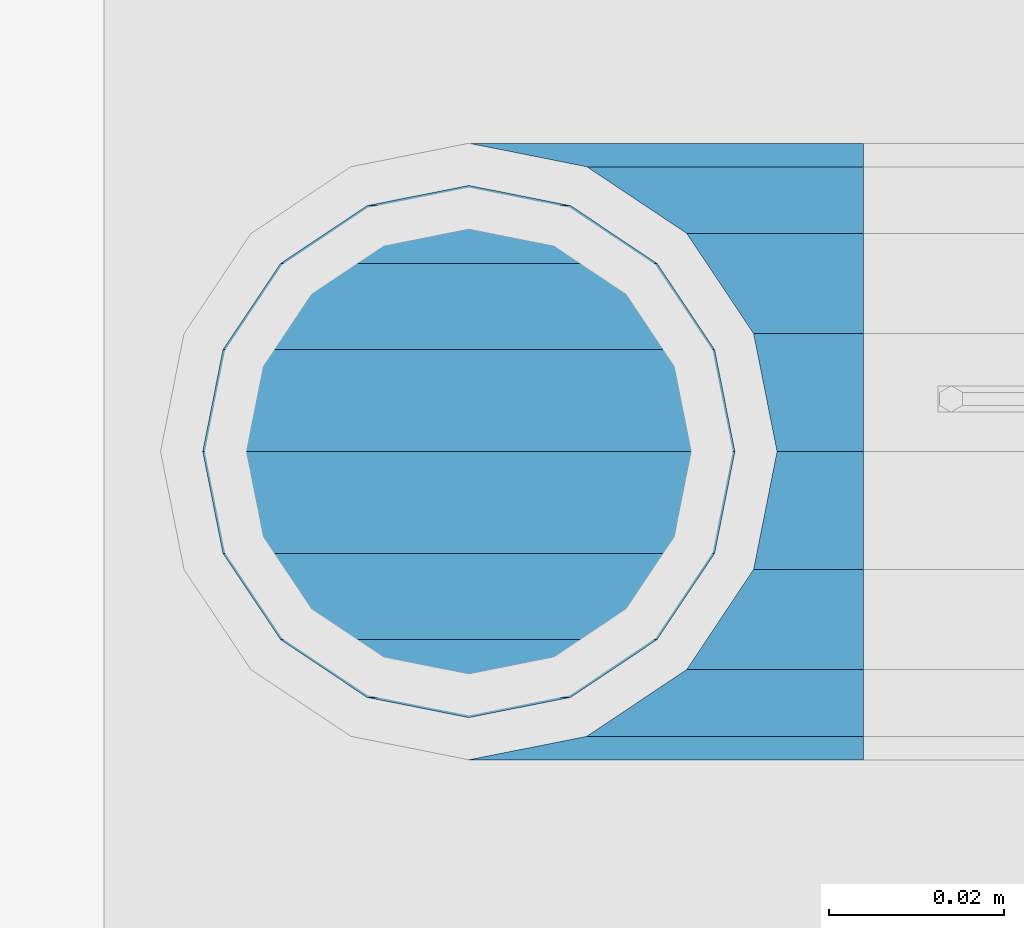
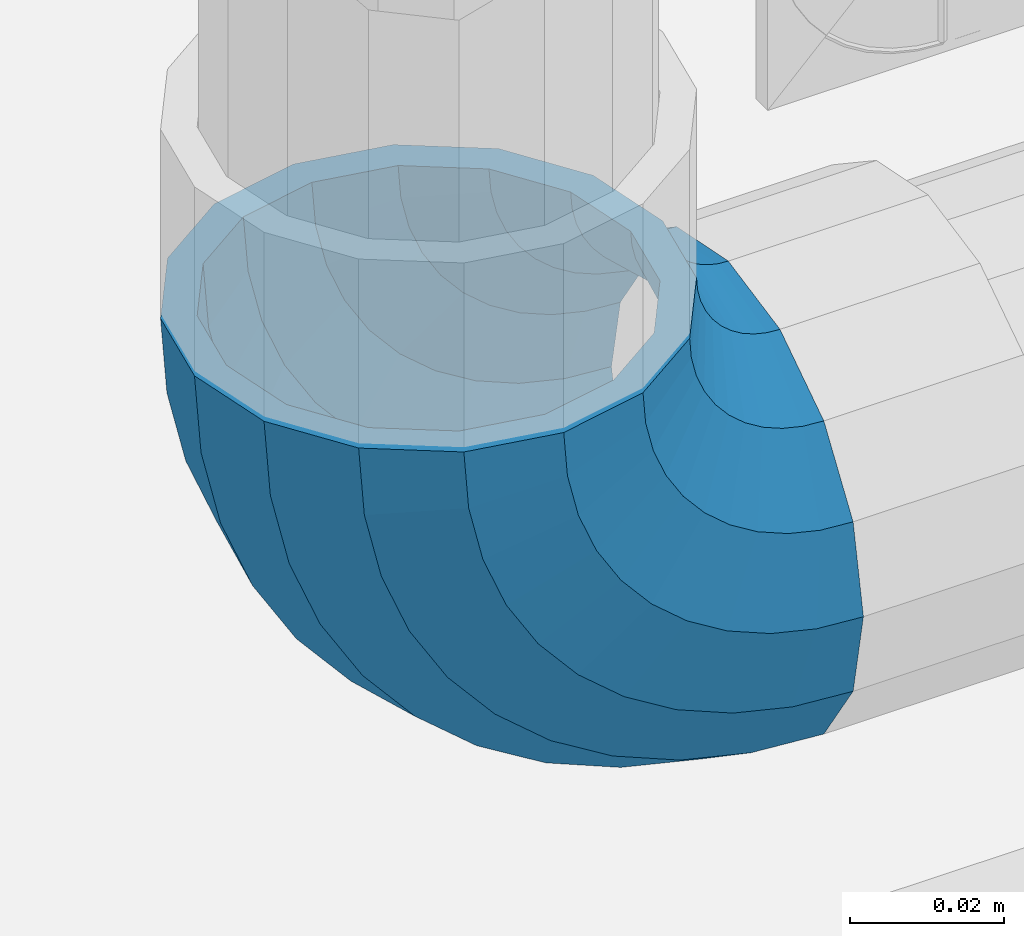
# One storey, part 127 of 193: 1 member.
"""IFC2X3 building model written with IfcOpenShell, lengths in millimetres."""

from ifc_helpers import new_model, si_unit, frame, origin_with_axes, place, context, subcontext, project, spatial, faceted_brep, material, type_object, element, save


model = new_model("IFC2X3")

# Units and contexts
model_context = context("Model", 3, precision=1e-05, world=origin_with_axes())
body_context = subcontext(model_context, "Body", "Model", "MODEL_VIEW")
ifc_project = project(units=[si_unit("LENGTHUNIT", "METRE", prefix="MILLI"), si_unit("AREAUNIT", "SQUARE_METRE"), si_unit("VOLUMEUNIT", "CUBIC_METRE"), si_unit("MASSUNIT", "GRAM", prefix="KILO"), si_unit("TIMEUNIT", "SECOND"), si_unit("PLANEANGLEUNIT", "RADIAN"), si_unit("SOLIDANGLEUNIT", "STERADIAN"), si_unit("THERMODYNAMICTEMPERATUREUNIT", "DEGREE_CELSIUS"), si_unit("LUMINOUSINTENSITYUNIT", "LUMEN")], contexts=[model_context])

# Site, building, storey
site_placement = place(None, origin_with_axes())
site = spatial("IfcSite", under=ifc_project, at=site_placement, CompositionType="ELEMENT")
building_placement = place(site_placement, origin_with_axes())
building = spatial("IfcBuilding", under=site, at=building_placement, Name="Standard", CompositionType="ELEMENT")
storey_placement = place(building_placement, origin_with_axes())
storey = spatial("IfcBuildingStorey", under=building, at=storey_placement, Name="Undefined", CompositionType="ELEMENT", Elevation=0.0)

# Member
ifc_material = material(Name="Misc_Undefined")
member_type = type_object("IfcMemberType", PredefinedType="NOTDEFINED")
member_placement = place(storey_placement, frame((-30118.39, 28664.5, 343.170000000002), z_axis=(-0.707106781186548, 0.0, -0.707106781186548), x_axis=(0.707106781186548, 0.0, -0.707106781186548)))
element("IfcMember", 1, at=member_placement, inside=storey, type_object=member_type, material=ifc_material, context=body_context, shape_type="Brep", body=[
    faceted_brep([(0.0, -35.1500000000015, 0.0), (9.51152146007007, -32.4743655677703, -9.51152146007007), (13.2759578763398, -32.4743655677703, -6.2963890252795), (5.36946880023243, -35.1500000000015, 4.58595959347804), (17.5749999999971, -24.8548033587067, -17.5750000000007), (19.978755663109, -24.8548033587067, -15.5219987155651), (22.9628441077002, -13.4513226476338, -22.9628441077002), (24.4574219585229, -13.4513226476338, -21.6863540323939), (24.8548033587067, 0.0, -24.8548033587067), (26.0301204183124, 0.0, -23.850987758804), (22.9628441077002, 13.4513226476338, -22.9628441077002), (24.4574219585229, 13.4513226476338, -21.6863540323939), (17.5749999999971, 24.8548033587067, -17.5750000000007), (19.978755663109, 24.8548033587067, -15.5219987155651), (9.51152146007007, 32.4743655677703, -9.51152146007007), (13.2759578763398, 32.4743655677703, -6.2963890252795), (0.0, 35.1500000000015, 0.0), (5.36946880023243, 35.1500000000015, 4.58595959347804), (-9.51152146007007, 32.4743655677703, 9.51152146007007), (-2.53702027587133, 32.4743655677703, 15.4683082122356), (-17.5750000000007, 24.8548033587067, 17.5750000000007), (-9.23981806264419, 24.8548033587067, 24.6939179025212), (-22.9628441077039, 13.4513226476338, 22.9628441077002), (-13.718484358058, 13.4513226476338, 30.8582732193499), (-24.8548033587103, 0.0, 24.8548033587067), (-15.2911828178476, 0.0, 33.02290694576), (-22.9628441077039, -13.4513226476338, 22.9628441077002), (-13.718484358058, -13.4513226476338, 30.8582732193499), (-17.5750000000007, -24.8548033587067, 17.5750000000007), (-9.23981806264419, -24.8548033587067, 24.6939179025212), (-9.51152146007007, -32.4743655677703, 9.51152146007007), (-2.53702027587133, -32.4743655677703, 15.4683082122356), (0.0, -30.3499999999985, 0.0), (-8.2126508197216, -28.0397438117179, 8.21265081971796), (-1.45732902223972, -28.0397438117179, 13.9822406910389), (5.36946880023243, -30.3499999999985, 4.58595959347804), (-15.1749999999993, -21.46069080901, 15.1749999999993), (-7.24480876131565, -21.46069080901, 21.9480231689959), (-19.827092992, -11.614442172282, 19.827092992), (-11.1118790903529, -11.614442172282, 27.2705888550809), (-21.4606908090136, 0.0, 21.46069080901), (-12.4698136068437, 0.0, 29.139625372758), (-19.827092992, 11.614442172282, 19.827092992), (-11.1118790903529, 11.614442172282, 27.2705888550809), (-15.1749999999993, 21.46069080901, 15.1749999999993), (-7.24480876131565, 21.46069080901, 21.9480231689959), (-8.2126508197216, 28.0397438117179, 8.21265081971796), (-1.45732902223972, 28.0397438117179, 13.9822406910389), (0.0, 30.3499999999985, 0.0), (5.36946880023243, 30.3499999999985, 4.58595959347804), (8.21265081971796, 28.0397438117179, -8.2126508197216), (12.1962666227009, 28.0397438117179, -4.81032150408282), (15.1749999999956, 21.46069080901, -15.1749999999993), (17.9837463617769, 21.46069080901, -12.7761039820398), (19.8270929919963, 11.614442172282, -19.827092992), (21.8508166908177, 11.614442172282, -18.0986696681211), (21.46069080901, 0.0, -21.46069080901), (23.2087512073085, 0.0, -19.9677061858019), (19.8270929919963, -11.614442172282, -19.827092992), (21.8508166908177, -11.614442172282, -18.0986696681211), (15.1749999999956, -21.46069080901, -15.1749999999993), (17.9837463617769, -21.46069080901, -12.7761039820398), (8.21265081971796, -28.0397438117179, -8.2126508197216), (12.1962666227009, -28.0397438117179, -4.81032150408282), (17.4970053560683, -32.4743655677703, -3.70972780292141), (11.3902326651114, -35.1500000000015, 8.27548843508339), (22.6740772628618, -24.8548033587067, -13.8703035149447), (26.1332861179508, -13.4513226476338, -20.6593831546779), (27.3479987309584, 0.0, -23.0433908901396), (26.1332861179508, 13.4513226476338, -20.6593831546779), (22.6740772628618, 24.8548033587067, -13.8703035149447), (17.4970053560683, 32.4743655677703, -3.70972780292141), (11.3902326651114, 35.1500000000015, 8.27548843508339), (5.28345997415818, 32.4743655677703, 20.2607046730882), (0.106388067368243, 24.8548033587067, 30.4212803851115), (-3.35282078772434, 13.4513226476338, 37.2103600248483), (-4.56753340073192, 0.0, 39.5943677603027), (-3.35282078772434, -13.4513226476338, 37.2103600248483), (0.106388067368243, -24.8548033587067, 30.4212803851115), (5.28345997415818, -32.4743655677703, 20.2607046730882), (6.11738625912403, -28.0397438117179, 18.6240321853948), (11.3902326651114, -30.3499999999985, 8.27548843508339), (1.6472829199738, -21.46069080901, 27.3971039594981), (-1.3395446405375, -11.614442172282, 33.259083107896), (-2.38837900198268, 0.0, 35.3175364441995), (-1.3395446405375, 11.614442172282, 33.259083107896), (1.6472829199738, 21.46069080901, 27.3971039594981), (6.11738625912403, 28.0397438117179, 18.6240321853948), (11.3902326651114, 30.3499999999985, 8.27548843508339), (16.6630790711024, 28.0397438117179, -2.07305531522434), (21.1331824102526, 21.46069080901, -10.8461270893349), (24.1200099707639, 11.614442172282, -16.7081062377292), (25.1688443322091, 0.0, -18.7665595740327), (24.1200099707639, -11.614442172282, -16.7081062377292), (21.1331824102526, -21.46069080901, -10.8461270893349), (16.6630790711024, -28.0397438117179, -2.07305531522434), (22.070727701459, -32.4743655677703, -1.81522997693173), (17.9140404065183, -35.1500000000015, 10.9777380798878), (25.5945970362081, -24.8548033587067, -12.6605846156453), (27.9491712485069, -13.4513226476338, -19.9072189058934), (28.7759877587996, 0.0, -22.4518984678871), (27.9491712485069, 13.4513226476338, -19.9072189058934), (25.5945970362081, 24.8548033587067, -12.6605846156453), (22.070727701459, 32.4743655677703, -1.81522997693173), (17.9140404065183, 35.1500000000015, 10.9777380798878), (13.7573531115813, 32.4743655677703, 23.7707061367037), (10.2334837768358, 24.8548033587067, 34.6160607754209), (7.87890956453339, 13.4513226476338, 41.8626950656653), (7.05209305424069, 0.0, 44.407374627659), (7.87890956453339, -13.4513226476338, 41.8626950656653), (10.2334837768358, -24.8548033587067, 34.6160607754209), (13.7573531115813, -32.4743655677703, 23.7707061367037), (14.3249803951003, -28.0397438117179, 22.0237289909674), (17.9140404065183, -30.3499999999985, 10.9777380798878), (11.2823222355109, -21.46069080901, 31.3880679179965), (9.24928305077992, -11.614442172282, 37.6451191472661), (8.53537462723762, 0.0, 39.8423033494473), (9.24928305077992, 11.614442172282, 37.6451191472661), (11.2823222355109, 21.46069080901, 31.3880679179965), (14.3249803951003, 28.0397438117179, 22.0237289909674), (17.9140404065183, 30.3499999999985, 10.9777380798878), (21.50310041794, 28.0397438117179, -0.0682528311917849), (24.545758577533, 21.46069080901, -9.43259175821731), (26.5787977622604, 11.614442172282, -15.6896429874942), (27.2927061858027, 0.0, -17.8868271896717), (26.5787977622604, -11.614442172282, -15.6896429874942), (24.545758577533, -21.46069080901, -9.43259175821731), (21.50310041794, -28.0397438117179, -0.0682528311917849), (26.8845046890456, -32.4743655677703, -0.659544371261291), (24.7802542265854, -35.1500000000015, 12.6261701733893), (28.6684020936846, -24.8548033587067, -11.9226293117936), (29.8603642316994, -13.4513226476338, -19.4483820661262), (30.2789256727447, 0.0, -22.0910749985305), (29.8603642316994, 13.4513226476338, -19.4483820661262), (28.6684020936846, 24.8548033587067, -11.9226293117936), (26.8845046890456, 32.4743655677703, -0.659544371261291), (24.7802542265854, 35.1500000000015, 12.6261701733893), (22.6760037641179, 32.4743655677703, 25.9118847180362), (20.8921063594826, 24.8548033587067, 37.1749696585684), (19.7001442214678, 13.4513226476338, 44.7007224129011), (19.2815827804188, 0.0, 47.3434153453054), (19.7001442214678, -13.4513226476338, 44.7007224129011), (20.8921063594826, -24.8548033587067, 37.1749696585684), (22.6760037641179, -32.4743655677703, 25.9118847180362), (22.963355178621, -28.0397438117179, 24.0976192894668), (24.7802542265854, -30.3499999999985, 12.6261701733893), (21.4230625404816, -21.46069080901, 33.8226442665655), (20.3938719035323, -11.614442172282, 40.3206982094962), (20.032468212612, 0.0, 42.6025113104479), (20.3938719035323, 11.614442172282, 40.3206982094962), (21.4230625404816, 21.46069080901, 33.8226442665655), (22.963355178621, 28.0397438117179, 24.0976192894668), (24.7802542265854, 30.3499999999985, 12.6261701733893), (26.5971532745461, 28.0397438117179, 1.15472105730805), (28.1374459126819, 21.46069080901, -8.5703039197906), (29.1666365496349, 11.614442172282, -15.0683578627213), (29.5280402405551, 0.0, -17.3501709636766), (29.1666365496349, -11.614442172282, -15.0683578627213), (28.1374459126819, -21.46069080901, -8.5703039197906), (26.5971532745461, -28.0397438117179, 1.15472105730805), (31.8198051533946, -32.4743655677703, -0.271127801028342), (31.8198051533946, -35.1500000000015, 13.1801948466054), (31.8198051533946, -24.8548033587067, -11.6746085121013), (31.8198051533946, -13.4513226476338, -19.2941707211648), (31.8198051533909, 0.0, -21.969805153396), (31.8198051533946, 13.4513226476338, -19.2941707211648), (31.8198051533946, 24.8548033587067, -11.6746085121013), (31.8198051533946, 32.4743655677703, -0.271127801028342), (31.8198051533946, 35.1500000000015, 13.1801948466054), (31.8198051533946, 32.4743655677703, 26.6315174942392), (31.8198051533909, 24.8548033587067, 38.0349982053121), (31.8198051533946, 13.4513226476338, 45.6545604143794), (31.8198051533946, 0.0, 48.3301948466069), (31.8198051533946, -13.4513226476338, 45.6545604143794), (31.8198051533909, -24.8548033587067, 38.0349982053121), (31.8198051533946, -32.4743655677703, 26.6315174942392), (31.8198051533909, -28.0397438117179, 24.7946370188874), (31.8198051533946, -30.3499999999985, 13.1801948466054), (31.8198051533946, -21.46069080901, 34.6408856556154), (31.8198051533946, -11.614442172282, 41.219938658327), (31.8198051533909, 0.0, 43.530194846604), (31.8198051533946, 11.614442172282, 41.219938658327), (31.8198051533946, 21.46069080901, 34.6408856556154), (31.8198051533909, 28.0397438117179, 24.7946370188874), (31.8198051533946, 30.3499999999985, 13.1801948466054), (31.8198051533946, 28.0397438117179, 1.56575267432709), (31.8198051533909, 21.46069080901, -8.28049596240453), (31.8198051533946, 11.614442172282, -14.8595489651125), (31.8198051533909, 0.0, -17.1698051533931), (31.8198051533946, -11.614442172282, -14.8595489651125), (31.8198051533909, -21.46069080901, -8.28049596240453), (31.8198051533946, -28.0397438117179, 1.56575267432709), (36.7551056177363, -32.4743655677703, -0.659544371264928), (38.8593560802037, -35.1500000000015, 12.6261701733893), (34.9712082131009, -24.8548033587067, -11.9226293117936), (33.7792460750898, -13.4513226476338, -19.4483820661226), (33.3606846340372, 0.0, -22.0910749985305), (33.7792460750898, 13.4513226476338, -19.4483820661226), (34.9712082131009, 24.8548033587067, -11.9226293117936), (36.7551056177363, 32.4743655677703, -0.659544371264928), (38.8593560802037, 35.1500000000015, 12.6261701733893), (40.9636065426712, 32.4743655677703, 25.9118847180362), (42.7475039473065, 24.8548033587067, 37.1749696585684), (43.9394660853177, 13.4513226476338, 44.7007224128974), (44.3580275263666, 0.0, 47.343415345309), (43.9394660853177, -13.4513226476338, 44.7007224128974), (42.7475039473065, -24.8548033587067, 37.1749696585684), (40.9636065426712, -32.4743655677703, 25.9118847180362), (40.6762551281645, -28.0397438117179, 24.0976192894632), (38.8593560802037, -30.3499999999985, 12.6261701733893), (42.2165477663038, -21.46069080901, 33.8226442665655), (43.2457384032568, -11.614442172282, 40.3206982094962), (43.6071420941771, 0.0, 42.6025113104515), (43.2457384032568, 11.614442172282, 40.3206982094962), (42.2165477663038, 21.46069080901, 33.8226442665655), (40.6762551281645, 28.0397438117179, 24.0976192894632), (38.8593560802037, 30.3499999999985, 12.6261701733893), (37.042457032243, 28.0397438117179, 1.15472105730805), (35.5021643941, 21.46069080901, -8.5703039197906), (34.4729737571543, 11.614442172282, -15.0683578627213), (34.1115700662303, 0.0, -17.3501709636766), (34.4729737571543, -11.614442172282, -15.0683578627213), (35.5021643941, -21.46069080901, -8.5703039197906), (37.042457032243, -28.0397438117179, 1.15472105730805), (41.5688826053265, -32.4743655677703, -1.81522997693173), (45.7255699002671, -35.1500000000015, 10.9777380798878), (38.0450132705773, -24.8548033587067, -12.6605846156453), (35.6904390582786, -13.4513226476338, -19.9072189058897), (34.8636225479859, 0.0, -22.4518984678834), (35.6904390582786, 13.4513226476338, -19.9072189058897), (38.0450132705773, 24.8548033587067, -12.6605846156453), (41.5688826053265, 32.4743655677703, -1.81522997693173), (45.7255699002671, 35.1500000000015, 10.9777380798878), (49.8822571952041, 32.4743655677703, 23.7707061367073), (53.4061265299533, 24.8548033587067, 34.6160607754173), (55.7607007422557, 13.4513226476338, 41.862695065669), (56.5875172525448, 0.0, 44.4073746276626), (55.7607007422557, -13.4513226476338, 41.862695065669), (53.4061265299533, -24.8548033587067, 34.6160607754173), (49.8822571952041, -32.4743655677703, 23.7707061367073), (49.3146299116852, -28.0397438117179, 22.0237289909674), (45.7255699002671, -30.3499999999985, 10.9777380798878), (52.3572880712782, -21.46069080901, 31.3880679179929), (54.3903272560092, -11.614442172282, 37.6451191472697), (55.1042356795442, 0.0, 39.8423033494437), (54.3903272560092, 11.614442172282, 37.6451191472697), (52.3572880712782, 21.46069080901, 31.3880679179929), (49.3146299116852, 28.0397438117179, 22.0237289909674), (45.7255699002671, 30.3499999999985, 10.9777380798878), (42.1365098888455, 28.0397438117179, -0.0682528311954229), (39.0938517292525, 21.46069080901, -9.43259175821731), (37.0608125445215, 11.614442172282, -15.6896429874905), (36.3469041209864, 0.0, -17.8868271896681), (37.0608125445215, -11.614442172282, -15.6896429874905), (39.0938517292525, -21.46069080901, -9.43259175821731), (42.1365098888455, -28.0397438117179, -0.0682528311954229), (46.1426049507172, -32.4743655677703, -3.70972780292141), (52.2493776416704, -35.1500000000015, 8.27548843508339), (40.9655330439236, -24.8548033587067, -13.8703035149447), (37.5063241888347, -13.4513226476338, -20.6593831546816), (36.2916115758235, 0.0, -23.0433908901359), (37.5063241888347, 13.4513226476338, -20.6593831546816), (40.9655330439236, 24.8548033587067, -13.8703035149447), (46.1426049507172, 32.4743655677703, -3.70972780292141), (52.2493776416704, 35.1500000000015, 8.27548843508339), (58.3561503326309, 32.4743655677703, 20.2607046730882), (63.5332222394209, 24.8548033587067, 30.4212803851115), (66.9924310945134, 13.4513226476338, 37.2103600248447), (68.2071437075174, 0.0, 39.5943677603027), (66.9924310945134, -13.4513226476338, 37.2103600248447), (63.5332222394209, -24.8548033587067, 30.4212803851115), (58.3561503326309, -32.4743655677703, 20.2607046730882), (57.5222240476651, -28.0397438117179, 18.6240321853911), (52.2493776416704, -30.3499999999985, 8.27548843508339), (61.9923273868117, -21.46069080901, 27.3971039595017), (64.9791549473193, -11.614442172282, 33.259083107896), (66.0279893087682, 0.0, 35.3175364441995), (64.9791549473193, 11.614442172282, 33.259083107896), (61.9923273868117, 21.46069080901, 27.3971039595017), (57.5222240476651, 28.0397438117179, 18.6240321853911), (52.2493776416704, 30.3499999999985, 8.27548843508339), (46.9765312356831, 28.0397438117179, -2.07305531522798), (42.5064278965328, 21.46069080901, -10.8461270893386), (39.5196003360215, 11.614442172282, -16.7081062377292), (38.4707659745764, 0.0, -18.7665595740364), (39.5196003360215, -11.614442172282, -16.7081062377292), (42.5064278965328, -21.46069080901, -10.8461270893386), (46.9765312356831, -28.0397438117179, -2.07305531522798), (50.3636524304493, -32.4743655677703, -6.29638902527586), (58.2701415065567, -35.1500000000015, 4.58595959347804), (43.6608546436801, -24.8548033587067, -15.5219987155615), (39.1821883482626, -13.4513226476338, -21.6863540323939), (37.6094898884767, 0.0, -23.8509877588003), (39.1821883482626, 13.4513226476338, -21.6863540323939), (43.6608546436801, 24.8548033587067, -15.5219987155615), (50.3636524304493, 32.4743655677703, -6.29638902527586), (58.2701415065567, 35.1500000000015, 4.58595959347804), (66.1766305826604, 32.4743655677703, 15.4683082122319), (72.8794283694333, 24.8548033587067, 24.6939179025212), (77.3580946648435, 13.4513226476338, 30.8582732193499), (78.9307931246331, 0.0, 33.0229069457564), (77.3580946648435, -13.4513226476338, 30.8582732193499), (72.8794283694333, -24.8548033587067, 24.6939179025212), (66.1766305826604, -32.4743655677703, 15.4683082122319), (65.0969393290252, -28.0397438117179, 13.9822406910425), (58.2701415065567, -30.3499999999985, 4.58595959347804), (70.8844190680975, -21.46069080901, 21.9480231689959), (74.751489397142, -11.614442172282, 27.2705888550772), (76.1094239136291, 0.0, 29.1396253727617), (74.751489397142, 11.614442172282, 27.2705888550772), (70.8844190680975, 21.46069080901, 21.9480231689959), (65.0969393290252, 28.0397438117179, 13.9822406910425), (58.2701415065567, 30.3499999999985, 4.58595959347804), (51.4433436840845, 28.0397438117179, -4.81032150407918), (45.6558639450086, 21.46069080901, -12.7761039820361), (41.7887936159677, 11.614442172282, -18.0986696681211), (40.4308590994769, 0.0, -19.9677061857983), (41.7887936159677, -11.614442172282, -18.0986696681211), (45.6558639450086, -21.46069080901, -12.7761039820361), (51.4433436840845, -28.0397438117179, -4.81032150407918), (54.128088846719, -32.4743655677703, -9.51152146007007), (63.6396103067891, -35.1500000000015, 0.0), (46.0646103067884, -24.8548033587067, -17.5750000000007), (40.6767661990889, -13.4513226476338, -22.9628441077002), (38.7848069480824, 0.0, -24.8548033587067), (40.6767661990889, 13.4513226476338, -22.9628441077002), (46.0646103067884, 24.8548033587067, -17.5750000000007), (54.128088846719, 32.4743655677703, -9.51152146007007), (63.6396103067891, 35.1500000000015, 0.0), (73.1511317668592, 32.4743655677703, 9.51152146007007), (81.2146103067898, 24.8548033587067, 17.5750000000007), (86.602454414493, 13.4513226476338, 22.9628441077039), (88.4944136654958, 0.0, 24.8548033587067), (86.602454414493, -13.4513226476338, 22.9628441077039), (81.2146103067898, -24.8548033587067, 17.5750000000007), (73.1511317668592, -32.4743655677703, 9.51152146007007), (71.8522611265071, -28.0397438117179, 8.21265081971796), (63.6396103067891, -30.3499999999985, 0.0), (78.8146103067884, -21.46069080901, 15.1749999999993), (83.4667032987891, -11.614442172282, 19.827092992), (85.1003011158027, 0.0, 21.4606908090136), (83.4667032987891, 11.614442172282, 19.827092992), (78.8146103067884, 21.46069080901, 15.1749999999993), (71.8522611265071, 28.0397438117179, 8.21265081971796), (63.6396103067891, 30.3499999999985, 0.0), (55.4269594870711, 28.0397438117179, -8.21265081971796), (48.4646103067898, 21.46069080901, -15.1749999999993), (43.8125173147891, 11.614442172282, -19.8270929919963), (42.1789194977791, 0.0, -21.46069080901), (43.8125173147891, -11.614442172282, -19.8270929919963), (48.4646103067898, -21.46069080901, -15.1749999999993), (55.4269594870711, -28.0397438117179, -8.21265081971796)], [[[0, 1, 2, 3]], [[1, 4, 5, 2]], [[4, 6, 7, 5]], [[6, 8, 9, 7]], [[8, 10, 11, 9]], [[10, 12, 13, 11]], [[12, 14, 15, 13]], [[14, 16, 17, 15]], [[16, 18, 19, 17]], [[18, 20, 21, 19]], [[20, 22, 23, 21]], [[22, 24, 25, 23]], [[24, 26, 27, 25]], [[26, 28, 29, 27]], [[28, 30, 31, 29]], [[30, 0, 3, 31]], [[32, 33, 34, 35]], [[33, 36, 37, 34]], [[36, 38, 39, 37]], [[38, 40, 41, 39]], [[40, 42, 43, 41]], [[42, 44, 45, 43]], [[44, 46, 47, 45]], [[46, 48, 49, 47]], [[48, 50, 51, 49]], [[50, 52, 53, 51]], [[52, 54, 55, 53]], [[54, 56, 57, 55]], [[56, 58, 59, 57]], [[58, 60, 61, 59]], [[60, 62, 63, 61]], [[62, 32, 35, 63]], [[30, 28, 26, 24, 22, 20, 18, 16, 14, 12, 10, 8, 6, 4, 1, 0], [62, 60, 58, 56, 54, 52, 50, 48, 46, 44, 42, 40, 38, 36, 33, 32]], [[3, 2, 64, 65]], [[2, 5, 66, 64]], [[5, 7, 67, 66]], [[7, 9, 68, 67]], [[9, 11, 69, 68]], [[11, 13, 70, 69]], [[13, 15, 71, 70]], [[15, 17, 72, 71]], [[17, 19, 73, 72]], [[19, 21, 74, 73]], [[21, 23, 75, 74]], [[23, 25, 76, 75]], [[25, 27, 77, 76]], [[27, 29, 78, 77]], [[29, 31, 79, 78]], [[31, 3, 65, 79]], [[35, 34, 80, 81]], [[34, 37, 82, 80]], [[37, 39, 83, 82]], [[39, 41, 84, 83]], [[41, 43, 85, 84]], [[43, 45, 86, 85]], [[45, 47, 87, 86]], [[47, 49, 88, 87]], [[49, 51, 89, 88]], [[51, 53, 90, 89]], [[53, 55, 91, 90]], [[55, 57, 92, 91]], [[57, 59, 93, 92]], [[59, 61, 94, 93]], [[61, 63, 95, 94]], [[63, 35, 81, 95]], [[65, 64, 96, 97]], [[64, 66, 98, 96]], [[66, 67, 99, 98]], [[67, 68, 100, 99]], [[68, 69, 101, 100]], [[69, 70, 102, 101]], [[70, 71, 103, 102]], [[71, 72, 104, 103]], [[72, 73, 105, 104]], [[73, 74, 106, 105]], [[74, 75, 107, 106]], [[75, 76, 108, 107]], [[76, 77, 109, 108]], [[77, 78, 110, 109]], [[78, 79, 111, 110]], [[79, 65, 97, 111]], [[81, 80, 112, 113]], [[80, 82, 114, 112]], [[82, 83, 115, 114]], [[83, 84, 116, 115]], [[84, 85, 117, 116]], [[85, 86, 118, 117]], [[86, 87, 119, 118]], [[87, 88, 120, 119]], [[88, 89, 121, 120]], [[89, 90, 122, 121]], [[90, 91, 123, 122]], [[91, 92, 124, 123]], [[92, 93, 125, 124]], [[93, 94, 126, 125]], [[94, 95, 127, 126]], [[95, 81, 113, 127]], [[97, 96, 128, 129]], [[96, 98, 130, 128]], [[98, 99, 131, 130]], [[99, 100, 132, 131]], [[100, 101, 133, 132]], [[101, 102, 134, 133]], [[102, 103, 135, 134]], [[103, 104, 136, 135]], [[104, 105, 137, 136]], [[105, 106, 138, 137]], [[106, 107, 139, 138]], [[107, 108, 140, 139]], [[108, 109, 141, 140]], [[109, 110, 142, 141]], [[110, 111, 143, 142]], [[111, 97, 129, 143]], [[113, 112, 144, 145]], [[112, 114, 146, 144]], [[114, 115, 147, 146]], [[115, 116, 148, 147]], [[116, 117, 149, 148]], [[117, 118, 150, 149]], [[118, 119, 151, 150]], [[119, 120, 152, 151]], [[120, 121, 153, 152]], [[121, 122, 154, 153]], [[122, 123, 155, 154]], [[123, 124, 156, 155]], [[124, 125, 157, 156]], [[125, 126, 158, 157]], [[126, 127, 159, 158]], [[127, 113, 145, 159]], [[129, 128, 160, 161]], [[128, 130, 162, 160]], [[130, 131, 163, 162]], [[131, 132, 164, 163]], [[132, 133, 165, 164]], [[133, 134, 166, 165]], [[134, 135, 167, 166]], [[135, 136, 168, 167]], [[136, 137, 169, 168]], [[137, 138, 170, 169]], [[138, 139, 171, 170]], [[139, 140, 172, 171]], [[140, 141, 173, 172]], [[141, 142, 174, 173]], [[142, 143, 175, 174]], [[143, 129, 161, 175]], [[145, 144, 176, 177]], [[144, 146, 178, 176]], [[146, 147, 179, 178]], [[147, 148, 180, 179]], [[148, 149, 181, 180]], [[149, 150, 182, 181]], [[150, 151, 183, 182]], [[151, 152, 184, 183]], [[152, 153, 185, 184]], [[153, 154, 186, 185]], [[154, 155, 187, 186]], [[155, 156, 188, 187]], [[156, 157, 189, 188]], [[157, 158, 190, 189]], [[158, 159, 191, 190]], [[159, 145, 177, 191]], [[161, 160, 192, 193]], [[160, 162, 194, 192]], [[162, 163, 195, 194]], [[163, 164, 196, 195]], [[164, 165, 197, 196]], [[165, 166, 198, 197]], [[166, 167, 199, 198]], [[167, 168, 200, 199]], [[168, 169, 201, 200]], [[169, 170, 202, 201]], [[170, 171, 203, 202]], [[171, 172, 204, 203]], [[172, 173, 205, 204]], [[173, 174, 206, 205]], [[174, 175, 207, 206]], [[175, 161, 193, 207]], [[177, 176, 208, 209]], [[176, 178, 210, 208]], [[178, 179, 211, 210]], [[179, 180, 212, 211]], [[180, 181, 213, 212]], [[181, 182, 214, 213]], [[182, 183, 215, 214]], [[183, 184, 216, 215]], [[184, 185, 217, 216]], [[185, 186, 218, 217]], [[186, 187, 219, 218]], [[187, 188, 220, 219]], [[188, 189, 221, 220]], [[189, 190, 222, 221]], [[190, 191, 223, 222]], [[191, 177, 209, 223]], [[193, 192, 224, 225]], [[192, 194, 226, 224]], [[194, 195, 227, 226]], [[195, 196, 228, 227]], [[196, 197, 229, 228]], [[197, 198, 230, 229]], [[198, 199, 231, 230]], [[199, 200, 232, 231]], [[200, 201, 233, 232]], [[201, 202, 234, 233]], [[202, 203, 235, 234]], [[203, 204, 236, 235]], [[204, 205, 237, 236]], [[205, 206, 238, 237]], [[206, 207, 239, 238]], [[207, 193, 225, 239]], [[209, 208, 240, 241]], [[208, 210, 242, 240]], [[210, 211, 243, 242]], [[211, 212, 244, 243]], [[212, 213, 245, 244]], [[213, 214, 246, 245]], [[214, 215, 247, 246]], [[215, 216, 248, 247]], [[216, 217, 249, 248]], [[217, 218, 250, 249]], [[218, 219, 251, 250]], [[219, 220, 252, 251]], [[220, 221, 253, 252]], [[221, 222, 254, 253]], [[222, 223, 255, 254]], [[223, 209, 241, 255]], [[225, 224, 256, 257]], [[224, 226, 258, 256]], [[226, 227, 259, 258]], [[227, 228, 260, 259]], [[228, 229, 261, 260]], [[229, 230, 262, 261]], [[230, 231, 263, 262]], [[231, 232, 264, 263]], [[232, 233, 265, 264]], [[233, 234, 266, 265]], [[234, 235, 267, 266]], [[235, 236, 268, 267]], [[236, 237, 269, 268]], [[237, 238, 270, 269]], [[238, 239, 271, 270]], [[239, 225, 257, 271]], [[241, 240, 272, 273]], [[240, 242, 274, 272]], [[242, 243, 275, 274]], [[243, 244, 276, 275]], [[244, 245, 277, 276]], [[245, 246, 278, 277]], [[246, 247, 279, 278]], [[247, 248, 280, 279]], [[248, 249, 281, 280]], [[249, 250, 282, 281]], [[250, 251, 283, 282]], [[251, 252, 284, 283]], [[252, 253, 285, 284]], [[253, 254, 286, 285]], [[254, 255, 287, 286]], [[255, 241, 273, 287]], [[257, 256, 288, 289]], [[256, 258, 290, 288]], [[258, 259, 291, 290]], [[259, 260, 292, 291]], [[260, 261, 293, 292]], [[261, 262, 294, 293]], [[262, 263, 295, 294]], [[263, 264, 296, 295]], [[264, 265, 297, 296]], [[265, 266, 298, 297]], [[266, 267, 299, 298]], [[267, 268, 300, 299]], [[268, 269, 301, 300]], [[269, 270, 302, 301]], [[270, 271, 303, 302]], [[271, 257, 289, 303]], [[273, 272, 304, 305]], [[272, 274, 306, 304]], [[274, 275, 307, 306]], [[275, 276, 308, 307]], [[276, 277, 309, 308]], [[277, 278, 310, 309]], [[278, 279, 311, 310]], [[279, 280, 312, 311]], [[280, 281, 313, 312]], [[281, 282, 314, 313]], [[282, 283, 315, 314]], [[283, 284, 316, 315]], [[284, 285, 317, 316]], [[285, 286, 318, 317]], [[286, 287, 319, 318]], [[287, 273, 305, 319]], [[289, 288, 320, 321]], [[288, 290, 322, 320]], [[290, 291, 323, 322]], [[291, 292, 324, 323]], [[292, 293, 325, 324]], [[293, 294, 326, 325]], [[294, 295, 327, 326]], [[295, 296, 328, 327]], [[296, 297, 329, 328]], [[297, 298, 330, 329]], [[298, 299, 331, 330]], [[299, 300, 332, 331]], [[300, 301, 333, 332]], [[301, 302, 334, 333]], [[302, 303, 335, 334]], [[303, 289, 321, 335]], [[305, 304, 336, 337]], [[304, 306, 338, 336]], [[306, 307, 339, 338]], [[307, 308, 340, 339]], [[308, 309, 341, 340]], [[309, 310, 342, 341]], [[310, 311, 343, 342]], [[311, 312, 344, 343]], [[312, 313, 345, 344]], [[313, 314, 346, 345]], [[314, 315, 347, 346]], [[315, 316, 348, 347]], [[316, 317, 349, 348]], [[317, 318, 350, 349]], [[318, 319, 351, 350]], [[319, 305, 337, 351]], [[322, 323, 324, 325, 326, 327, 328, 329, 330, 331, 332, 333, 334, 335, 321, 320], [338, 339, 340, 341, 342, 343, 344, 345, 346, 347, 348, 349, 350, 351, 337, 336]]]),
])

save(model, "model.ifc")
